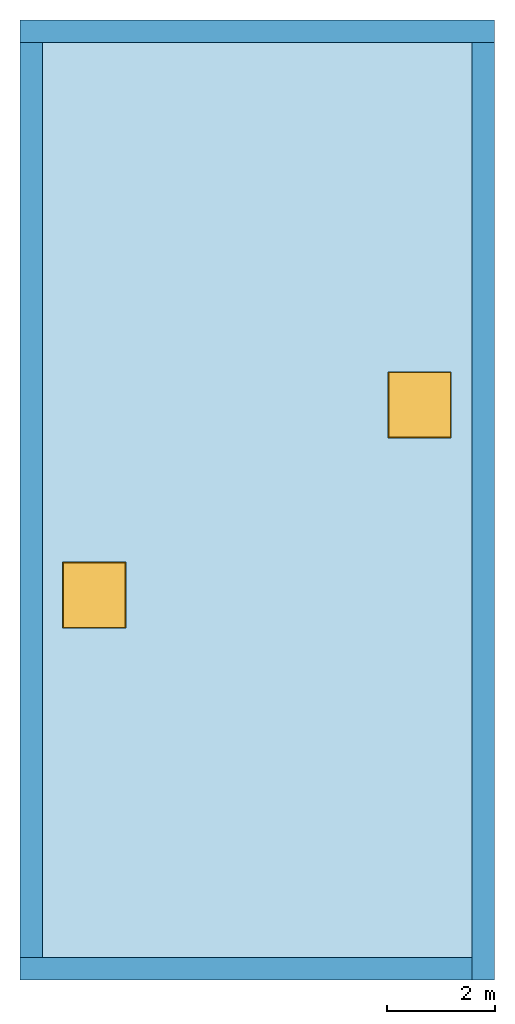
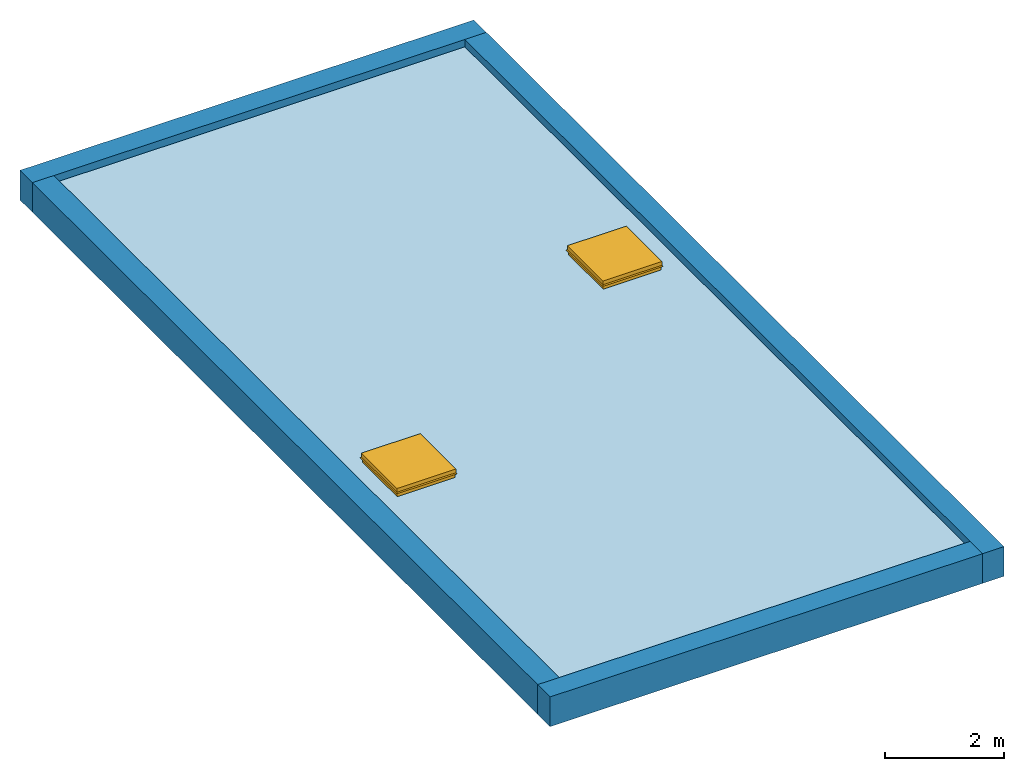
# One storey: 4 walls, 2 windows, 1 slab, 4 openings, 1 element without a shape of its own.
"""IFC2X3 building model written with IfcOpenShell, lengths in metres."""

from ifc_helpers import new_model, entity, si_unit, converted_unit, frame, frame_2d, origin, origin_2d_with_axis, place, context, project, spatial, rectangle, extrude, face_set, surface_model, source, transform, mapped, material, layer, layer_set, layer_usage, type_object, type_shapes, element, fill, aggregate, save


model = new_model("IFC2X3")

# Units and contexts
model_context = context("Model", 3, precision=1e-09, world=origin())
plan_context = context("Plan", 3, precision=1e-09, world=origin())
ifc_project = project(units=[si_unit("LENGTHUNIT", "METRE"), si_unit("AREAUNIT", "SQUARE_METRE"), si_unit("VOLUMEUNIT", "CUBIC_METRE"), converted_unit("PLANEANGLEUNIT", "DEGREE", entity("IfcRatioMeasure", 0.0174532925199433), si_unit("PLANEANGLEUNIT", "RADIAN"), dimensions=[0, 0, 0, 0, 0, 0, 0]), si_unit("TIMEUNIT", "SECOND")], contexts=[model_context, plan_context])

# Site, building, storey
site_placement = place(None, origin())
site = spatial("IfcSite", under=ifc_project, at=site_placement, CompositionType="ELEMENT")
building_placement = place(site_placement, origin())
building = spatial("IfcBuilding", under=site, at=building_placement, CompositionType="ELEMENT")
storey_placement = place(building_placement, frame((0.0, 0.0, 6.0)))
storey = spatial("IfcBuildingStorey", under=building, at=storey_placement, Name="Roof", CompositionType="ELEMENT", Elevation=6.00000000000039)

# Roof, openings, slab, windows
ifc_material_1 = material(Name="Site - Grass")
ifc_layer_1 = layer(ifc_material_1, 0.064)
ifc_material_2 = material(Name="Roofing - Barrier")
ifc_layer_2 = layer(ifc_material_2, 0.006)
ifc_material_3 = material(Name="Roofing - EPDM Membrane")
ifc_layer_3 = layer(ifc_material_3, 0.006)
ifc_material_4 = material(Name="Insulation / Thermal Barriers - Rigid insulation")
ifc_layer_4 = layer(ifc_material_4, 0.076)
ifc_material_5 = material(Name="Wood - Sheathing - plywood")
ifc_layer_5 = layer(ifc_material_5, 0.019)
ifc_material_6 = material(Name="Wood - Dimensional Lumber")
ifc_layer_6 = layer(ifc_material_6, 0.286)
ifc_layer_set_1 = layer_set([ifc_layer_1, ifc_layer_2, ifc_layer_3, ifc_layer_4, ifc_layer_5, ifc_layer_6])
ifc_layer_usage_1 = layer_usage(ifc_layer_set_1, "AXIS3", "NEGATIVE", 0.0)
roof_placement = place(storey_placement, origin())
roof = element("IfcRoof", 1, at=roof_placement, inside=storey, material=ifc_layer_usage_1, ShapeType="NOTDEFINED")
opening_1_placement = place(roof_placement, frame((0.416999999999999, -17.383, 0.0)))
opening_1 = element("IfcOpeningElement", 2, at=opening_1_placement, cuts=roof, ObjectType="Opening", context=model_context, shape_type="SweptSolid", body=[
    extrude(rectangle(XDim=1.0291, YDim=1.08109999999996, at=origin_2d_with_axis()), frame((0.959000000000025, 6.71799999999998, -1.067), z_axis=(0.0, 0.0, 1.0), x_axis=(-1.0, 0.0, 0.0)), (0.0, 0.0, 1.0), 3.048),
])
opening_2_placement = place(roof_placement, frame((0.416999999999999, -17.383, 0.0)))
opening_2 = element("IfcOpeningElement", 3, at=opening_2_placement, cuts=roof, ObjectType="Opening", context=model_context, shape_type="SweptSolid", body=[
    extrude(rectangle(XDim=1.0291, YDim=1.08109999999996, at=origin_2d_with_axis()), frame((6.99200000000003, 10.248, -1.067), z_axis=(0.0, 0.0, 1.0), x_axis=(-1.0, 0.0, 0.0)), (0.0, 0.0, 1.0), 3.048),
])
slab_placement = place(roof_placement, frame((0.416999999999999, -17.383, 0.0)))
slab = element("IfcSlab", 4, at=slab_placement, PredefinedType="ROOF", context=model_context, shape_type="SweptSolid", body=[
    extrude(rectangle(XDim=7.966, YDim=16.966, at=origin_2d_with_axis()), frame((3.983, 8.483, 0.0)), (0.0, 0.0, 1.0), 0.457),
])
opening_3_placement = place(roof_placement, frame((1.37600000000002, -10.665, 0.0)))
element("IfcOpeningElement", 5, at=opening_3_placement, cuts=slab, ObjectType="Opening", context=model_context, shape_type="SweptSolid", body=[
    extrude(rectangle(XDim=1.0291, YDim=1.08109999999996, at=origin_2d_with_axis()), frame((0.0, 0.0, 0.0), z_axis=(0.0, 0.0, 1.0), x_axis=(-1.0, 0.0, 0.0)), (0.0, 0.0, 1.0), 0.457),
])
opening_4_placement = place(roof_placement, frame((7.40900000000003, -7.13500000000003, 0.0)))
element("IfcOpeningElement", 6, at=opening_4_placement, cuts=slab, ObjectType="Opening", context=model_context, shape_type="SweptSolid", body=[
    extrude(rectangle(XDim=1.0291, YDim=1.08109999999996, at=origin_2d_with_axis()), frame((0.0, 0.0, 0.0), z_axis=(0.0, 0.0, 1.0), x_axis=(-1.0, 0.0, 0.0)), (0.0, 0.0, 1.0), 0.457),
])
aggregate(roof, [slab])
window_style = type_object("IfcWindowStyle", Name="1180 x 1170mm", ConstructionType="NOTDEFINED", OperationType="NOTDEFINED", ParameterTakesPrecedence=False, Sizeable=False)
shared_shape = source(origin(), model_context, "Body", "SurfaceModel", [
    surface_model("IfcFaceBasedSurfaceModel", [(0.254440073027717, 0.37010409881197, 4.267), (0.279840073027739, 0.395504098811992, 4.267), (0.279840073027739, -0.77449590118804, 4.267), (0.254440073027717, -0.749095901188018, 4.267), (0.254440073027717, 0.37010409881197, 4.2924), (0.254440073027717, -0.749095901188018, 4.2924), (0.292540073027718, 0.408204098811971, 4.2924), (0.292540073027718, -0.787195901188019, 4.2924), (0.292540073027718, 0.408204098811971, 4.267), (0.292540073027718, -0.787195901188019, 4.267), (0.292540073027718, 0.408204098811971, 4.2162), (0.292540073027718, -0.787195901188019, 4.2162), (0.307108914511034, 0.422772940295288, 4.19539353807506), (0.307108914511034, -0.801764742671336, 4.19539353807506), (0.301907299029799, 0.417571324814053, 4.19175132770423), (0.301907299029799, -0.796563127190101, 4.19175132770423), (0.286190073027718, 0.401854098811971, 4.21419785269062), (0.286190073027718, -0.780845901188019, 4.21419785269062), (0.286190073027718, 0.401854098811971, 4.267), (0.286190073027718, -0.780845901188019, 4.267), (-0.838159926972257, -0.77449590118804, 4.267), (-0.812759926972235, -0.749095901188018, 4.267), (-0.812759926972235, -0.749095901188018, 4.2924), (-0.850859926972236, -0.787195901188019, 4.2924), (-0.850859926972236, -0.787195901188019, 4.267), (-0.850859926972236, -0.787195901188019, 4.2162), (-0.865428768455553, -0.801764742671336, 4.19539353807506), (-0.860227152974318, -0.796563127190101, 4.19175132770423), (-0.844509926972236, -0.780845901188019, 4.21419785269062), (-0.844509926972236, -0.780845901188019, 4.267), (-0.838159926972257, 0.395504098811992, 4.267), (-0.812759926972235, 0.37010409881197, 4.267), (-0.812759926972235, 0.37010409881197, 4.2924), (-0.850859926972236, 0.408204098811971, 4.2924), (-0.850859926972236, 0.408204098811971, 4.267), (-0.850859926972236, 0.408204098811971, 4.2162), (-0.865428768455553, 0.422772940295288, 4.19539353807506), (-0.860227152974318, 0.417571324814053, 4.19175132770423), (-0.844509926972236, 0.401854098811971, 4.21419785269062), (-0.844509926972236, 0.401854098811971, 4.267), (0.279840073027754, -0.774495901188029, 4.267), (0.279840073027754, -0.774495901188029, 4.1146), (0.279840073027754, 0.395504098811972, 4.1146), (0.279840073027754, 0.395504098811972, 4.267), (0.254440073027754, -0.749095901188028, 4.267), (0.254440073027754, 0.370104098811971, 4.267), (0.254440073027754, -0.749095901188028, 4.2416), (0.254440073027754, 0.370104098811971, 4.2416), (0.235390073027754, -0.730045901188029, 4.2416), (0.235390073027754, 0.351054098811972, 4.2416), (0.235390073027754, -0.730045901188029, 4.1146), (0.235390073027754, 0.351054098811972, 4.1146), (-0.838159926972271, 0.395504098811972, 4.1146), (-0.838159926972271, 0.395504098811972, 4.267), (-0.812759926972271, 0.370104098811971, 4.267), (-0.812759926972271, 0.370104098811971, 4.2416), (-0.793709926972271, 0.351054098811972, 4.2416), (-0.793709926972271, 0.351054098811972, 4.1146), (-0.838159926972271, -0.774495901188029, 4.267), (-0.838159926972271, -0.774495901188029, 4.1146), (-0.812759926972271, -0.749095901188028, 4.267), (-0.812759926972271, -0.749095901188028, 4.2416), (-0.793709926972271, -0.730045901188029, 4.2416), (-0.793709926972271, -0.730045901188029, 4.1146), (0.254440073027753, -0.749095901188029, 4.2924), (-0.812759926972291, -0.749095901188028, 4.2924), (-0.812759926972291, 0.37010409881193, 4.2924), (0.254440073027753, 0.37010409881193, 4.2924), (0.254440073027753, -0.749095901188029, 4.28605), (-0.812759926972291, -0.749095901188028, 4.28605), (-0.812759926972291, 0.37010409881193, 4.28605), (0.254440073027753, 0.37010409881193, 4.28605)], [face_set([[[0, 1, 2, 3]], [[4, 5, 3, 0]], [[6, 7, 5, 4]], [[8, 6, 7, 9]], [[10, 8, 9, 11]], [[12, 13, 11, 10]], [[14, 12, 13, 15]], [[16, 14, 15, 17]], [[18, 19, 17, 16]], [[1, 18, 19, 2]], [[3, 2, 20, 21]], [[5, 22, 21, 3]], [[7, 23, 22, 5]], [[9, 7, 23, 24]], [[11, 9, 24, 25]], [[13, 26, 25, 11]], [[15, 13, 26, 27]], [[17, 15, 27, 28]], [[19, 29, 28, 17]], [[2, 19, 29, 20]], [[21, 20, 30, 31]], [[22, 21, 31, 32]], [[23, 33, 32, 22]], [[24, 34, 33, 23]], [[25, 35, 34, 24]], [[26, 36, 35, 25]], [[27, 26, 36, 37]], [[28, 27, 37, 38]], [[29, 28, 38, 39]], [[20, 29, 39, 30]], [[31, 30, 1, 0]], [[32, 4, 0, 31]], [[33, 6, 4, 32]], [[34, 33, 6, 8]], [[35, 34, 8, 10]], [[36, 12, 10, 35]], [[37, 36, 12, 14]], [[38, 37, 14, 16]], [[39, 18, 16, 38]], [[30, 39, 18, 1]]]), face_set([[[40, 41, 42, 43]], [[44, 45, 43, 40]], [[46, 47, 45, 44]], [[48, 49, 47, 46]], [[50, 51, 49, 48]], [[41, 50, 51, 42]], [[43, 42, 52, 53]], [[45, 54, 53, 43]], [[47, 55, 54, 45]], [[49, 56, 55, 47]], [[51, 57, 56, 49]], [[42, 51, 57, 52]], [[53, 58, 59, 52]], [[54, 60, 58, 53]], [[55, 54, 60, 61]], [[56, 62, 61, 55]], [[57, 56, 62, 63]], [[52, 57, 63, 59]], [[58, 59, 41, 40]], [[60, 44, 40, 58]], [[61, 46, 44, 60]], [[62, 48, 46, 61]], [[63, 50, 48, 62]], [[59, 63, 50, 41]]]), face_set([[[64, 65, 66, 67]], [[68, 69, 70, 71]], [[67, 64, 68, 71]], [[66, 67, 71, 70]], [[65, 69, 70, 66]], [[64, 65, 69, 68]]])]),
])
type_shapes(window_style, [shared_shape])
window_1_placement = place(opening_1_placement, frame((1.23815992697227, 6.90749590118803, -3.65760000000018)))
window_1 = element("IfcWindow", 7, at=window_1_placement, inside=storey, type_object=window_style, Name="M_Skylight:1180 x 1170mm:1180 x 1170mm", ObjectType="1180 x 1170mm", OverallHeight=0.634800000000001, OverallWidth=1.17253768296659, context=model_context, shape_type="MappedRepresentation", body=[
    mapped(shared_shape, transform((0.0, 0.0, 0.0), scale=1.0)),
])
fill(opening_1, window_1)
window_2_placement = place(opening_2_placement, frame((7.27115992697228, 10.437495901188, -3.65760000000018)))
window_2 = element("IfcWindow", 8, at=window_2_placement, inside=storey, type_object=window_style, Name="M_Skylight:1180 x 1170mm:1180 x 1170mm", ObjectType="1180 x 1170mm", OverallHeight=0.634800000000001, OverallWidth=1.17253768296659, context=model_context, shape_type="MappedRepresentation", body=[
    mapped(shared_shape, transform((0.0, 0.0, 0.0), scale=1.0)),
])
fill(opening_2, window_2)

# Walls
ifc_material_7 = material(Name="Masonry - Brick")
ifc_layer_7 = layer(ifc_material_7, 0.092)
ifc_material_8 = material(Name="Misc. Air Layers - Air Space")
ifc_layer_8 = layer(ifc_material_8, 0.025)
ifc_layer_9 = layer(ifc_material_4, 0.05)
ifc_material_9 = material(Name="Masonry - Concrete Block")
ifc_layer_10 = layer(ifc_material_9, 0.193)
ifc_material_10 = material(Name="Metal - Stud Layer")
ifc_layer_11 = layer(ifc_material_10, 0.041)
ifc_material_11 = material(Name="Plasterboard")
ifc_layer_12 = layer(ifc_material_11, 0.016)
ifc_layer_set_2 = layer_set([ifc_layer_7, ifc_layer_8, ifc_layer_9, ifc_layer_10, ifc_layer_11, ifc_layer_12], Name="Basic Wall:Exterior - Brick on Block")
ifc_layer_usage_2 = layer_usage(ifc_layer_set_2, "AXIS2", "NEGATIVE", 0.2085)
wall_1_placement = place(storey_placement, frame((0.0, -0.2085, 0.0)))
element("IfcWallStandardCase", 9, at=wall_1_placement, inside=storey, material=ifc_layer_usage_2, Name="Basic Wall:Exterior - Brick on Block", ObjectType="Basic Wall:Exterior - Brick on Block", context=model_context, shape_type="SweptSolid", body=[
    extrude(rectangle(XDim=8.8, YDim=0.417, at=frame_2d((4.4, 0.0), x_axis=(-1.0, 0.0))), origin(), (0.0, 0.0, 1.0), 0.609),
])
ifc_layer_usage_3 = layer_usage(ifc_layer_set_2, "AXIS2", "NEGATIVE", 0.2085)
wall_2_placement = place(storey_placement, frame((8.5915, -0.417000000000028, 0.0), z_axis=(0.0, 0.0, 1.0), x_axis=(0.0, -1.0, 0.0)))
element("IfcWallStandardCase", 10, at=wall_2_placement, inside=storey, material=ifc_layer_usage_3, Name="Basic Wall:Exterior - Brick on Block", ObjectType="Basic Wall:Exterior - Brick on Block", context=model_context, shape_type="SweptSolid", body=[
    extrude(rectangle(XDim=17.383, YDim=0.417, at=frame_2d((8.69149999999999, 0.0), x_axis=(-1.0, 0.0))), origin(), (0.0, 0.0, 1.0), 0.609),
])
ifc_layer_usage_4 = layer_usage(ifc_layer_set_2, "AXIS2", "NEGATIVE", 0.2085)
wall_3_placement = place(storey_placement, frame((8.38299999999997, -17.5915, 0.0), z_axis=(0.0, 0.0, 1.0), x_axis=(-1.0, 0.0, 0.0)))
element("IfcWallStandardCase", 11, at=wall_3_placement, inside=storey, material=ifc_layer_usage_4, Name="Basic Wall:Exterior - Brick on Block", ObjectType="Basic Wall:Exterior - Brick on Block", context=model_context, shape_type="SweptSolid", body=[
    extrude(rectangle(XDim=8.38299999999997, YDim=0.417, at=frame_2d((4.19149999999999, 0.0), x_axis=(-1.0, 0.0))), origin(), (0.0, 0.0, 1.0), 0.609),
])
ifc_layer_usage_5 = layer_usage(ifc_layer_set_2, "AXIS2", "NEGATIVE", 0.2085)
wall_4_placement = place(storey_placement, frame((0.208499999999999, -17.383, 0.0), z_axis=(0.0, 0.0, 1.0), x_axis=(0.0, 1.0, 0.0)))
element("IfcWallStandardCase", 12, at=wall_4_placement, inside=storey, material=ifc_layer_usage_5, Name="Basic Wall:Exterior - Brick on Block", ObjectType="Basic Wall:Exterior - Brick on Block", context=model_context, shape_type="SweptSolid", body=[
    extrude(rectangle(XDim=16.966, YDim=0.417, at=frame_2d((8.48299999999999, 0.0), x_axis=(-1.0, 0.0))), origin(), (0.0, 0.0, 1.0), 0.609),
])

save(model, "model.ifc")
